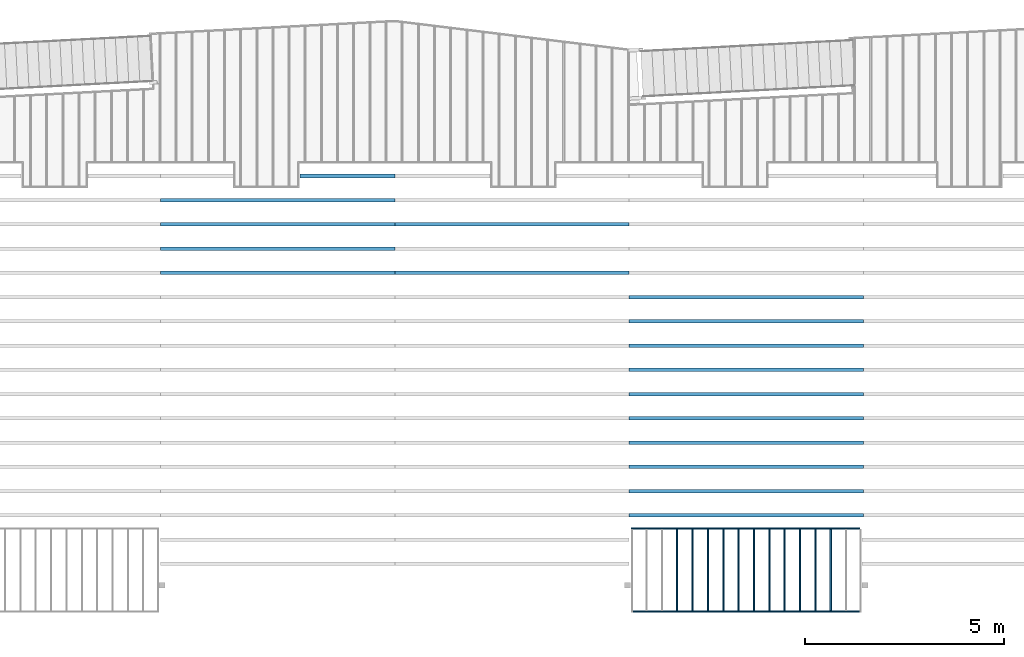
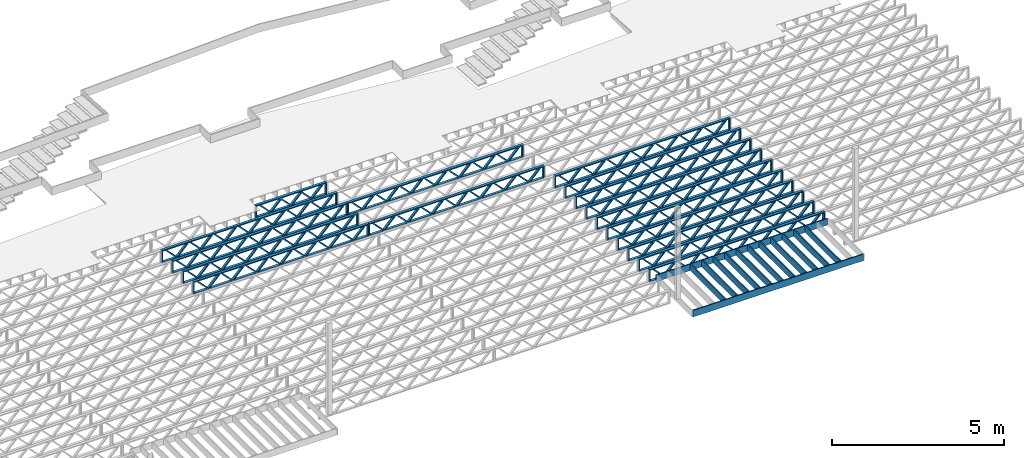
# One storey, part 7 of 23: 30 beams, 4 elements without a shape of their own.
"""IFC4 building model written with IfcOpenShell, lengths in feet."""

from ifc_helpers import new_model, entity, si_unit, converted_unit, derived_unit, direction, frame, frame_2d, origin, origin_2d_with_axis, place, context, subcontext, project, spatial, rectangle, extrude, source, transform, mapped, material, material_profile, profile_set, profile_usage, type_object, type_shapes, element, aggregate, save


model = new_model("IFC4")

# Units and contexts
model_context_1 = context("Model", 3, precision=0.0001, world=origin(), true_north=direction((6.12303176911189e-17, 1.0)))
model_context_2 = context("Model", 3, precision=0.0001, world=origin(), true_north=direction((6.12303176911189e-17, 1.0)))
body_context = subcontext(model_context_2, "Body", "Model", "MODEL_VIEW")
ifc_project = project(units=[converted_unit("LENGTHUNIT", "FOOT", entity("IfcRatioMeasure", 0.3048), si_unit("LENGTHUNIT", "METRE"), dimensions=[1, 0, 0, 0, 0, 0, 0]), converted_unit("AREAUNIT", "SQUARE FOOT", entity("IfcRatioMeasure", 0.09290304), si_unit("AREAUNIT", "SQUARE_METRE"), dimensions=[2, 0, 0, 0, 0, 0, 0]), converted_unit("VOLUMEUNIT", "CUBIC FOOT", entity("IfcRatioMeasure", 0.028316846592), si_unit("VOLUMEUNIT", "CUBIC_METRE"), dimensions=[3, 0, 0, 0, 0, 0, 0]), converted_unit("PLANEANGLEUNIT", "DEGREE", entity("IfcRatioMeasure", 0.0174532925199433), si_unit("PLANEANGLEUNIT", "RADIAN"), dimensions=[0, 0, 0, 0, 0, 0, 0]), si_unit("MASSUNIT", "GRAM", prefix="KILO"), derived_unit("MASSDENSITYUNIT", [(si_unit("MASSUNIT", "GRAM", prefix="KILO"), 1), (si_unit("LENGTHUNIT", "METRE"), -3)]), derived_unit("MOMENTOFINERTIAUNIT", [(si_unit("LENGTHUNIT", "METRE"), 4)]), si_unit("TIMEUNIT", "SECOND"), si_unit("FREQUENCYUNIT", "HERTZ"), si_unit("THERMODYNAMICTEMPERATUREUNIT", "DEGREE_CELSIUS"), derived_unit("THERMALTRANSMITTANCEUNIT", [(si_unit("MASSUNIT", "GRAM", prefix="KILO"), 1), (si_unit("THERMODYNAMICTEMPERATUREUNIT", "KELVIN"), -1), (si_unit("TIMEUNIT", "SECOND"), -3)]), derived_unit("VOLUMETRICFLOWRATEUNIT", [(si_unit("LENGTHUNIT", "METRE"), 3), (si_unit("TIMEUNIT", "SECOND"), -1)]), si_unit("ELECTRICCURRENTUNIT", "AMPERE"), si_unit("ELECTRICVOLTAGEUNIT", "VOLT"), si_unit("POWERUNIT", "WATT"), si_unit("FORCEUNIT", "NEWTON"), si_unit("ILLUMINANCEUNIT", "LUX"), si_unit("LUMINOUSFLUXUNIT", "LUMEN"), si_unit("LUMINOUSINTENSITYUNIT", "CANDELA"), derived_unit("USERDEFINED", [(si_unit("MASSUNIT", "GRAM", prefix="KILO"), -1), (si_unit("LENGTHUNIT", "METRE"), -2), (si_unit("TIMEUNIT", "SECOND"), 3), (si_unit("LUMINOUSFLUXUNIT", "LUMEN"), 1)]), derived_unit("LINEARVELOCITYUNIT", [(si_unit("LENGTHUNIT", "METRE"), 1), (si_unit("TIMEUNIT", "SECOND"), -1)]), si_unit("PRESSUREUNIT", "PASCAL"), derived_unit("USERDEFINED", [(si_unit("LENGTHUNIT", "METRE"), -2), (si_unit("MASSUNIT", "GRAM", prefix="KILO"), 1), (si_unit("TIMEUNIT", "SECOND"), -2)]), derived_unit("LINEARFORCEUNIT", [(si_unit("MASSUNIT", "GRAM", prefix="KILO"), 1), (si_unit("LENGTHUNIT", "METRE"), 1), (si_unit("TIMEUNIT", "SECOND"), -2), (si_unit("LENGTHUNIT", "METRE"), -1)]), derived_unit("PLANARFORCEUNIT", [(si_unit("MASSUNIT", "GRAM", prefix="KILO"), 1), (si_unit("LENGTHUNIT", "METRE"), 1), (si_unit("TIMEUNIT", "SECOND"), -2), (si_unit("LENGTHUNIT", "METRE"), -2)])], contexts=[model_context_1])

# Site, building, storey
site_placement = place(None, origin())
site = spatial("IfcSite", under=ifc_project, at=site_placement, CompositionType="ELEMENT")
building_placement = place(site_placement, origin())
building = spatial("IfcBuilding", under=site, at=building_placement, CompositionType="ELEMENT")
storey_placement = place(building_placement, frame((0.0, 0.0, 10.8020833333333)))
storey = spatial("IfcBuildingStorey", under=building, at=storey_placement, Name="2ND FLOOR", CompositionType="ELEMENT", Elevation=10.8020833333333)

# Assembly, beams
assembly_1_placement = place(storey_placement, origin())
assembly_1 = element("IfcElementAssembly", 1, at=assembly_1_placement, inside=storey, Name="Structural Beam System:Structural Framing System", ObjectType="Structural Beam System:Structural Framing System", AssemblyPlace="NOTDEFINED", PredefinedType="BEAM_GRID")
ifc_material_1 = material(Name="WOOD TRUSS", Category="Materials")
ifc_material_profile_1 = material_profile(ifc_material_1, rectangle(XDim=1.73473973950632, YDim=0.125, at=frame_2d((-1.11022302462516e-16, 8.32667268468867e-17), x_axis=(1.0, 0.0))))
ifc_material_profile_2 = material_profile(ifc_material_1, rectangle(XDim=1.73473973950633, YDim=0.125, at=frame_2d((-1.11022302462516e-16, 8.32667268468867e-17), x_axis=(1.0, 0.0))))
ifc_material_profile_3 = material_profile(ifc_material_1, rectangle(XDim=1.73473973950632, YDim=0.125, at=frame_2d((-5.55111512312578e-17, 1.38777878078145e-16), x_axis=(1.0, 0.0))))
ifc_material_profile_4 = material_profile(ifc_material_1, rectangle(XDim=1.73473973950633, YDim=0.125, at=frame_2d((-1.11022302462516e-16, 8.32667268468867e-17), x_axis=(1.0, 0.0))))
ifc_material_profile_5 = material_profile(ifc_material_1, rectangle(XDim=1.73473973950632, YDim=0.125, at=frame_2d((-1.11022302462516e-16, 8.32667268468867e-17), x_axis=(1.0, 0.0))))
ifc_material_profile_6 = material_profile(ifc_material_1, rectangle(XDim=1.73473973950633, YDim=0.125, at=frame_2d((-2.77555756156289e-16, 3.05311331771918e-16), x_axis=(1.0, 0.0))))
ifc_material_profile_7 = material_profile(ifc_material_1, rectangle(XDim=1.73473973950632, YDim=0.124999999999999, at=frame_2d((-3.88578058618805e-16, -2.4980018054066e-16), x_axis=(1.0, 0.0))))
ifc_material_profile_8 = material_profile(ifc_material_1, rectangle(XDim=1.73473973950633, YDim=0.125, at=frame_2d((2.77555756156289e-16, -3.05311331771918e-16), x_axis=(1.0, 0.0))))
ifc_material_profile_9 = material_profile(ifc_material_1, rectangle(XDim=1.73473973950632, YDim=0.124999999999999, at=frame_2d((-1.11022302462516e-16, 8.32667268468867e-17), x_axis=(1.0, 0.0))))
ifc_material_profile_10 = material_profile(ifc_material_1, rectangle(XDim=1.73473973950633, YDim=0.125, at=origin_2d_with_axis()))
ifc_material_profile_11 = material_profile(ifc_material_1, rectangle(XDim=0.124999999999982, YDim=0.291666666666668, at=origin_2d_with_axis()))
ifc_material_profile_12 = material_profile(ifc_material_1, rectangle(XDim=0.124999999999932, YDim=0.291666666666664, at=origin_2d_with_axis()))
ifc_material_profile_13 = material_profile(ifc_material_1, rectangle(XDim=1.25000000000002, YDim=0.29166666666667, at=origin_2d_with_axis()))
ifc_material_profile_14 = material_profile(ifc_material_1, rectangle(XDim=1.25000000000004, YDim=0.291666666666667, at=origin_2d_with_axis()))
ifc_profile_set_1 = profile_set([ifc_material_profile_1, ifc_material_profile_2, ifc_material_profile_3, ifc_material_profile_4, ifc_material_profile_5, ifc_material_profile_6, ifc_material_profile_7, ifc_material_profile_8, ifc_material_profile_9, ifc_material_profile_10, ifc_material_profile_11, ifc_material_profile_12, ifc_material_profile_13, ifc_material_profile_14])
ifc_profile_usage_1 = profile_usage(ifc_profile_set_1, cardinal=8)
beam_type_1 = type_object("IfcBeamType", PredefinedType="BEAM", material=ifc_profile_set_1)
shared_shape_1 = source(origin(), body_context, "Body", "SweptSolid", [
    extrude(rectangle(XDim=1.73473973950632, YDim=0.124999999999999, at=frame_2d((5.55111512312578e-16, 7.21644966006352e-16), x_axis=(1.0, 0.0))), frame((5.95847627016997, -0.145833333333334, 0.0), z_axis=(0.0, 1.0, 0.0), x_axis=(0.693383046997606, 0.0, 0.720569184836762)), (0.0, 0.0, 1.0), 0.291666666666667),
    extrude(rectangle(XDim=1.73473973950633, YDim=0.125, at=origin_2d_with_axis()), frame((4.7081903964967, -0.145833333333334, 0.0), z_axis=(0.0, 1.0, 0.0), x_axis=(0.69338304699761, 0.0, -0.720569184836758)), (0.0, 0.0, 1.0), 0.291666666666666),
    extrude(rectangle(XDim=1.73473973950632, YDim=0.125, at=frame_2d((2.22044604925031e-16, 3.88578058618805e-16), x_axis=(1.0, 0.0))), frame((3.29180960350347, -0.145833333333334, 0.0), z_axis=(0.0, 1.0, 0.0), x_axis=(0.693383046997606, 0.0, 0.720569184836762)), (0.0, 0.0, 1.0), 0.291666666666667),
    extrude(rectangle(XDim=1.73473973950633, YDim=0.125, at=frame_2d((1.11022302462516e-16, -8.32667268468867e-17), x_axis=(1.0, 0.0))), frame((2.0415237298302, -0.145833333333334, 0.0), z_axis=(0.0, 1.0, 0.0), x_axis=(0.69338304699761, 0.0, -0.720569184836758)), (0.0, 0.0, 1.0), 0.291666666666667),
    extrude(rectangle(XDim=1.73473973950632, YDim=0.125, at=frame_2d((-5.55111512312578e-17, 1.38777878078145e-16), x_axis=(1.0, 0.0))), frame((0.625142936836964, -0.145833333333334, 0.0), z_axis=(0.0, 1.0, 0.0), x_axis=(0.693383046997606, 0.0, 0.720569184836762)), (0.0, 0.0, 1.0), 0.291666666666667),
    extrude(rectangle(XDim=1.73473973950633, YDim=0.125, at=frame_2d((-1.11022302462516e-16, 8.32667268468867e-17), x_axis=(1.0, 0.0))), frame((-0.625142936836306, -0.145833333333334, 0.0), z_axis=(0.0, 1.0, 0.0), x_axis=(0.69338304699761, 0.0, -0.720569184836758)), (0.0, 0.0, 1.0), 0.291666666666667),
    extrude(rectangle(XDim=1.73473973950632, YDim=0.125, at=frame_2d((-1.11022302462516e-16, 8.32667268468867e-17), x_axis=(1.0, 0.0))), frame((-2.04152372982954, -0.145833333333334, 0.0), z_axis=(0.0, 1.0, 0.0), x_axis=(0.693383046997606, 0.0, 0.720569184836762)), (0.0, 0.0, 1.0), 0.291666666666667),
    extrude(rectangle(XDim=1.73473973950633, YDim=0.125, at=origin_2d_with_axis()), frame((-3.29180960350281, -0.145833333333334, 0.0), z_axis=(0.0, 1.0, 0.0), x_axis=(0.69338304699761, 0.0, -0.720569184836758)), (0.0, 0.0, 1.0), 0.291666666666667),
    extrude(rectangle(XDim=1.73473973950632, YDim=0.124999999999999, at=frame_2d((-1.11022302462516e-16, 8.32667268468867e-17), x_axis=(1.0, 0.0))), frame((-4.70819039649604, -0.145833333333334, 0.0), z_axis=(0.0, 1.0, 0.0), x_axis=(0.693383046997606, 0.0, 0.720569184836762)), (0.0, 0.0, 1.0), 0.291666666666667),
    extrude(rectangle(XDim=1.73473973950633, YDim=0.125, at=frame_2d((-5.55111512312578e-16, 6.38378239159465e-16), x_axis=(1.0, 0.0))), frame((-5.95847627016931, -0.145833333333334, 0.0), z_axis=(0.0, 1.0, 0.0), x_axis=(0.69338304699761, 0.0, -0.720569184836758)), (0.0, 0.0, 1.0), 0.291666666666666),
    extrude(rectangle(XDim=1.73473973950632, YDim=0.125, at=frame_2d((-7.21644966006352e-16, -5.82867087928207e-16), x_axis=(1.0, 0.0))), frame((8.62514293683647, -0.145833333333334, 0.0), z_axis=(0.0, 1.0, 0.0), x_axis=(0.693383046997607, 0.0, 0.720569184836761)), (0.0, 0.0, 1.0), 0.291666666666667),
    extrude(rectangle(XDim=1.73473973950633, YDim=0.125, at=origin_2d_with_axis()), frame((7.3748570631632, -0.145833333333334, 0.0), z_axis=(0.0, 1.0, 0.0), x_axis=(0.69338304699761, 0.0, -0.720569184836758)), (0.0, 0.0, 1.0), 0.291666666666666),
    extrude(rectangle(XDim=1.73473973950632, YDim=0.124999999999999, at=frame_2d((-1.11022302462516e-16, 8.32667268468867e-17), x_axis=(1.0, 0.0))), frame((-7.37485706316255, -0.145833333333334, 0.0), z_axis=(0.0, 1.0, 0.0), x_axis=(0.693383046997606, 0.0, 0.720569184836762)), (0.0, 0.0, 1.0), 0.291666666666667),
    extrude(rectangle(XDim=1.73473973950633, YDim=0.125, at=origin_2d_with_axis()), frame((-8.62514293683582, -0.145833333333334, 0.0), z_axis=(0.0, 1.0, 0.0), x_axis=(0.69338304699761, 0.0, -0.720569184836758)), (0.0, 0.0, 1.0), 0.291666666666666),
    extrude(rectangle(XDim=0.124999999999982, YDim=0.291666666666668, at=origin_2d_with_axis()), frame((-9.66666666666609, 0.0, 0.687500000000054), z_axis=(1.0, 0.0, 0.0), x_axis=(0.0, 0.0, -1.0)), (0.0, 0.0, 1.0), 19.3333333333322),
    extrude(rectangle(XDim=0.124999999999932, YDim=0.291666666666664, at=origin_2d_with_axis()), frame((-9.66666666666588, 0.0, -0.687499999999984), z_axis=(1.0, 0.0, 0.0), x_axis=(0.0, 0.0, -1.0)), (0.0, 0.0, 1.0), 19.333333333332),
    extrude(rectangle(XDim=1.25000000000002, YDim=0.29166666666667, at=origin_2d_with_axis()), frame((9.54166666666607, 0.0, 0.0), z_axis=(1.0, 0.0, 0.0), x_axis=(0.0, 0.0, -1.0)), (0.0, 0.0, 1.0), 0.12500000000002),
    extrude(rectangle(XDim=1.25000000000004, YDim=0.291666666666667, at=origin_2d_with_axis()), frame((-9.66666666666609, 0.0, 0.0), z_axis=(1.0, 0.0, 0.0), x_axis=(0.0, 0.0, -1.0)), (0.0, 0.0, 1.0), 0.125000000000023),
])
type_shapes(beam_type_1, [shared_shape_1])
beam_1_placement = place(assembly_1_placement, frame((-174.071493818896, 947.861934882651, -0.947916666666657), z_axis=(0.0, 0.0, 1.0), x_axis=(-1.0, 0.0, 0.0)))
beam_1 = element("IfcBeam", 2, at=beam_1_placement, type_object=beam_type_1, material=ifc_profile_usage_1, PredefinedType="BEAM", context=body_context, shape_type="MappedRepresentation", body=[
    mapped(shared_shape_1, transform((0.0, 0.0, 0.0), scale=1.0)),
])
ifc_profile_usage_2 = profile_usage(ifc_profile_set_1, cardinal=8)
beam_2_placement = place(assembly_1_placement, frame((-174.071493818896, 945.861934882651, -0.947916666666657), z_axis=(0.0, 0.0, 1.0), x_axis=(-1.0, 0.0, 0.0)))
beam_2 = element("IfcBeam", 3, at=beam_2_placement, type_object=beam_type_1, material=ifc_profile_usage_2, PredefinedType="BEAM", context=body_context, shape_type="MappedRepresentation", body=[
    mapped(shared_shape_1, transform((0.0, 0.0, 0.0), scale=1.0)),
])
ifc_profile_usage_3 = profile_usage(ifc_profile_set_1, cardinal=8)
beam_3_placement = place(assembly_1_placement, frame((-174.071493818896, 943.861934882651, -0.947916666666657), z_axis=(0.0, 0.0, 1.0), x_axis=(-1.0, 0.0, 0.0)))
beam_3 = element("IfcBeam", 4, at=beam_3_placement, type_object=beam_type_1, material=ifc_profile_usage_3, PredefinedType="BEAM", context=body_context, shape_type="MappedRepresentation", body=[
    mapped(shared_shape_1, transform((0.0, 0.0, 0.0), scale=1.0)),
])
ifc_profile_usage_4 = profile_usage(ifc_profile_set_1, cardinal=8)
beam_4_placement = place(assembly_1_placement, frame((-174.071493818896, 941.861934882651, -0.947916666666657), z_axis=(0.0, 0.0, 1.0), x_axis=(-1.0, 0.0, 0.0)))
beam_4 = element("IfcBeam", 5, at=beam_4_placement, type_object=beam_type_1, material=ifc_profile_usage_4, PredefinedType="BEAM", context=body_context, shape_type="MappedRepresentation", body=[
    mapped(shared_shape_1, transform((0.0, 0.0, 0.0), scale=1.0)),
])
ifc_profile_usage_5 = profile_usage(ifc_profile_set_1, cardinal=8)
beam_5_placement = place(assembly_1_placement, frame((-174.071493818896, 939.861934882651, -0.947916666666657), z_axis=(0.0, 0.0, 1.0), x_axis=(-1.0, 0.0, 0.0)))
beam_5 = element("IfcBeam", 6, at=beam_5_placement, type_object=beam_type_1, material=ifc_profile_usage_5, PredefinedType="BEAM", context=body_context, shape_type="MappedRepresentation", body=[
    mapped(shared_shape_1, transform((0.0, 0.0, 0.0), scale=1.0)),
])
ifc_profile_usage_6 = profile_usage(ifc_profile_set_1, cardinal=8)
beam_6_placement = place(assembly_1_placement, frame((-174.071493818896, 937.861934882651, -0.947916666666657), z_axis=(0.0, 0.0, 1.0), x_axis=(-1.0, 0.0, 0.0)))
beam_6 = element("IfcBeam", 7, at=beam_6_placement, type_object=beam_type_1, material=ifc_profile_usage_6, PredefinedType="BEAM", context=body_context, shape_type="MappedRepresentation", body=[
    mapped(shared_shape_1, transform((0.0, 0.0, 0.0), scale=1.0)),
])
ifc_profile_usage_7 = profile_usage(ifc_profile_set_1, cardinal=8)
beam_7_placement = place(assembly_1_placement, frame((-174.071493818896, 935.861934882651, -0.947916666666657), z_axis=(0.0, 0.0, 1.0), x_axis=(-1.0, 0.0, 0.0)))
beam_7 = element("IfcBeam", 8, at=beam_7_placement, type_object=beam_type_1, material=ifc_profile_usage_7, PredefinedType="BEAM", context=body_context, shape_type="MappedRepresentation", body=[
    mapped(shared_shape_1, transform((0.0, 0.0, 0.0), scale=1.0)),
])
ifc_profile_usage_8 = profile_usage(ifc_profile_set_1, cardinal=8)
beam_8_placement = place(assembly_1_placement, frame((-174.071493818896, 933.861934882651, -0.947916666666657), z_axis=(0.0, 0.0, 1.0), x_axis=(-1.0, 0.0, 0.0)))
beam_8 = element("IfcBeam", 9, at=beam_8_placement, type_object=beam_type_1, material=ifc_profile_usage_8, PredefinedType="BEAM", context=body_context, shape_type="MappedRepresentation", body=[
    mapped(shared_shape_1, transform((0.0, 0.0, 0.0), scale=1.0)),
])
ifc_profile_usage_9 = profile_usage(ifc_profile_set_1, cardinal=8)
beam_9_placement = place(assembly_1_placement, frame((-174.071493818896, 931.861934882651, -0.947916666666657), z_axis=(0.0, 0.0, 1.0), x_axis=(-1.0, 0.0, 0.0)))
beam_9 = element("IfcBeam", 10, at=beam_9_placement, type_object=beam_type_1, material=ifc_profile_usage_9, PredefinedType="BEAM", context=body_context, shape_type="MappedRepresentation", body=[
    mapped(shared_shape_1, transform((0.0, 0.0, 0.0), scale=1.0)),
])
ifc_profile_usage_10 = profile_usage(ifc_profile_set_1, cardinal=8)
beam_10_placement = place(assembly_1_placement, frame((-174.071493818896, 929.861934882651, -0.947916666666657), z_axis=(0.0, 0.0, 1.0), x_axis=(-1.0, 0.0, 0.0)))
beam_10 = element("IfcBeam", 11, at=beam_10_placement, type_object=beam_type_1, material=ifc_profile_usage_10, PredefinedType="BEAM", context=body_context, shape_type="MappedRepresentation", body=[
    mapped(shared_shape_1, transform((0.0, 0.0, 0.0), scale=1.0)),
])
aggregate(assembly_1, [beam_1, beam_2, beam_3, beam_4, beam_5, beam_6, beam_7, beam_8, beam_9, beam_10])

assembly_2_placement = place(storey_placement, origin())
assembly_2 = element("IfcElementAssembly", 12, at=assembly_2_placement, inside=storey, Name="Structural Beam System:Structural Framing System", ObjectType="Structural Beam System:Structural Framing System", AssemblyPlace="NOTDEFINED", PredefinedType="BEAM_GRID")
ifc_profile_usage_11 = profile_usage(ifc_profile_set_1, cardinal=8)
beam_11_placement = place(assembly_2_placement, frame((-193.404827152229, 953.861934882651, -0.947916666666881)))
beam_11 = element("IfcBeam", 13, at=beam_11_placement, type_object=beam_type_1, material=ifc_profile_usage_11, PredefinedType="BEAM", context=body_context, shape_type="MappedRepresentation", body=[
    mapped(shared_shape_1, transform((0.0, 0.0, 0.0), scale=1.0)),
])
ifc_profile_usage_12 = profile_usage(ifc_profile_set_1, cardinal=8)
beam_12_placement = place(assembly_2_placement, frame((-193.404827152229, 949.861934882651, -0.947916666666881)))
beam_12 = element("IfcBeam", 14, at=beam_12_placement, type_object=beam_type_1, material=ifc_profile_usage_12, PredefinedType="BEAM", context=body_context, shape_type="MappedRepresentation", body=[
    mapped(shared_shape_1, transform((0.0, 0.0, 0.0), scale=1.0)),
])
aggregate(assembly_2, [beam_11, beam_12])

assembly_3_placement = place(storey_placement, origin())
assembly_3 = element("IfcElementAssembly", 15, at=assembly_3_placement, inside=storey, Name="Structural Beam System:Structural Framing System", ObjectType="Structural Beam System:Structural Framing System", AssemblyPlace="NOTDEFINED", PredefinedType="BEAM_GRID")
ifc_profile_usage_13 = profile_usage(ifc_profile_set_1, cardinal=8)
beam_13_placement = place(assembly_3_placement, frame((-212.738160485495, 955.861934882651, -0.947916666666881), z_axis=(0.0, 0.0, 1.0), x_axis=(-1.0, 0.0, 0.0)))
beam_13 = element("IfcBeam", 16, at=beam_13_placement, type_object=beam_type_1, material=ifc_profile_usage_13, PredefinedType="BEAM", context=body_context, shape_type="MappedRepresentation", body=[
    mapped(shared_shape_1, transform((0.0, 0.0, 0.0), scale=1.0)),
])
ifc_profile_usage_14 = profile_usage(ifc_profile_set_1, cardinal=8)
beam_14_placement = place(assembly_3_placement, frame((-212.738160485495, 953.861934882651, -0.947916666666881), z_axis=(0.0, 0.0, 1.0), x_axis=(-1.0, 0.0, 0.0)))
beam_14 = element("IfcBeam", 17, at=beam_14_placement, type_object=beam_type_1, material=ifc_profile_usage_14, PredefinedType="BEAM", context=body_context, shape_type="MappedRepresentation", body=[
    mapped(shared_shape_1, transform((0.0, 0.0, 0.0), scale=1.0)),
])
ifc_profile_usage_15 = profile_usage(ifc_profile_set_1, cardinal=8)
beam_15_placement = place(assembly_3_placement, frame((-212.738160485495, 951.861934882651, -0.947916666666881), z_axis=(0.0, 0.0, 1.0), x_axis=(-1.0, 0.0, 0.0)))
beam_15 = element("IfcBeam", 18, at=beam_15_placement, type_object=beam_type_1, material=ifc_profile_usage_15, PredefinedType="BEAM", context=body_context, shape_type="MappedRepresentation", body=[
    mapped(shared_shape_1, transform((0.0, 0.0, 0.0), scale=1.0)),
])
ifc_profile_usage_16 = profile_usage(ifc_profile_set_1, cardinal=8)
beam_16_placement = place(assembly_3_placement, frame((-212.738160485495, 949.861934882651, -0.947916666666881), z_axis=(0.0, 0.0, 1.0), x_axis=(-1.0, 0.0, 0.0)))
beam_16 = element("IfcBeam", 19, at=beam_16_placement, type_object=beam_type_1, material=ifc_profile_usage_16, PredefinedType="BEAM", context=body_context, shape_type="MappedRepresentation", body=[
    mapped(shared_shape_1, transform((0.0, 0.0, 0.0), scale=1.0)),
])

assembly_4_placement = place(storey_placement, origin())
assembly_4 = element("IfcElementAssembly", 20, at=assembly_4_placement, inside=storey, Name="Structural Beam System:Structural Framing System", ObjectType="Structural Beam System:Structural Framing System", AssemblyPlace="NOTDEFINED", PredefinedType="BEAM_GRID")
ifc_material_2 = material(Category="Materials")
ifc_material_profile_15 = material_profile(ifc_material_2, rectangle(XDim=0.770833333333333, YDim=0.124999999999994, at=frame_2d((-5.55111512312578e-17, 0.0), x_axis=(1.0, 0.0))))
ifc_profile_set_2 = profile_set([ifc_material_profile_15])
ifc_profile_usage_17 = profile_usage(ifc_profile_set_2, cardinal=8)
beam_type_2 = type_object("IfcBeamType", PredefinedType="BEAM", material=ifc_profile_set_2)
shared_shape_2 = source(origin(), body_context, "Body", "SweptSolid", [
    extrude(rectangle(XDim=0.770833333333333, YDim=0.124999999999994, at=frame_2d((-5.55111512312578e-17, 0.0), x_axis=(1.0, 0.0))), frame((-3.35416666666737, 0.0, 0.0), z_axis=(1.0, 0.0, 0.0), x_axis=(0.0, 0.0, -1.0)), (0.0, 0.0, 1.0), 6.70833333333462),
])
type_shapes(beam_type_2, [shared_shape_2])
beam_17_placement = place(assembly_4_placement, frame((-167.102006703188, 925.341101549316, -0.645833333333471), z_axis=(0.0, 0.0, 1.0), x_axis=(0.0, 1.0, 0.0)))
beam_17 = element("IfcBeam", 21, at=beam_17_placement, type_object=beam_type_2, material=ifc_profile_usage_17, PredefinedType="BEAM", context=body_context, shape_type="MappedRepresentation", body=[
    mapped(shared_shape_2, transform((0.0, 0.0, 0.0), scale=1.0)),
])
ifc_profile_usage_18 = profile_usage(ifc_profile_set_2, cardinal=8)
beam_18_placement = place(assembly_4_placement, frame((-168.368890383746, 925.341101549316, -0.645833333333471), z_axis=(0.0, 0.0, 1.0), x_axis=(0.0, 1.0, 0.0)))
beam_18 = element("IfcBeam", 22, at=beam_18_placement, type_object=beam_type_2, material=ifc_profile_usage_18, PredefinedType="BEAM", context=body_context, shape_type="MappedRepresentation", body=[
    mapped(shared_shape_2, transform((0.0, 0.0, 0.0), scale=1.0)),
])
ifc_profile_usage_19 = profile_usage(ifc_profile_set_2, cardinal=8)
beam_19_placement = place(assembly_4_placement, frame((-169.635774064305, 925.341101549317, -0.645833333333471), z_axis=(0.0, 0.0, 1.0), x_axis=(0.0, 1.0, 0.0)))
beam_19 = element("IfcBeam", 23, at=beam_19_placement, type_object=beam_type_2, material=ifc_profile_usage_19, PredefinedType="BEAM", context=body_context, shape_type="MappedRepresentation", body=[
    mapped(shared_shape_2, transform((0.0, 0.0, 0.0), scale=1.0)),
])
ifc_profile_usage_20 = profile_usage(ifc_profile_set_2, cardinal=8)
beam_20_placement = place(assembly_4_placement, frame((-170.902657744863, 925.341101549317, -0.645833333333471), z_axis=(0.0, 0.0, 1.0), x_axis=(0.0, 1.0, 0.0)))
beam_20 = element("IfcBeam", 24, at=beam_20_placement, type_object=beam_type_2, material=ifc_profile_usage_20, PredefinedType="BEAM", context=body_context, shape_type="MappedRepresentation", body=[
    mapped(shared_shape_2, transform((0.0, 0.0, 0.0), scale=1.0)),
])
ifc_profile_usage_21 = profile_usage(ifc_profile_set_2, cardinal=8)
beam_21_placement = place(assembly_4_placement, frame((-172.169541425421, 925.341101549317, -0.645833333333471), z_axis=(0.0, 0.0, 1.0), x_axis=(0.0, 1.0, 0.0)))
beam_21 = element("IfcBeam", 25, at=beam_21_placement, type_object=beam_type_2, material=ifc_profile_usage_21, PredefinedType="BEAM", context=body_context, shape_type="MappedRepresentation", body=[
    mapped(shared_shape_2, transform((0.0, 0.0, 0.0), scale=1.0)),
])
ifc_profile_usage_22 = profile_usage(ifc_profile_set_2, cardinal=8)
beam_22_placement = place(assembly_4_placement, frame((-173.43642510598, 925.341101549317, -0.645833333333471), z_axis=(0.0, 0.0, 1.0), x_axis=(0.0, 1.0, 0.0)))
beam_22 = element("IfcBeam", 26, at=beam_22_placement, type_object=beam_type_2, material=ifc_profile_usage_22, PredefinedType="BEAM", context=body_context, shape_type="MappedRepresentation", body=[
    mapped(shared_shape_2, transform((0.0, 0.0, 0.0), scale=1.0)),
])
ifc_profile_usage_23 = profile_usage(ifc_profile_set_2, cardinal=8)
beam_23_placement = place(assembly_4_placement, frame((-174.703308786538, 925.341101549318, -0.645833333333433), z_axis=(0.0, 0.0, 1.0), x_axis=(0.0, 1.0, 0.0)))
beam_23 = element("IfcBeam", 27, at=beam_23_placement, type_object=beam_type_2, material=ifc_profile_usage_23, PredefinedType="BEAM", context=body_context, shape_type="MappedRepresentation", body=[
    mapped(shared_shape_2, transform((0.0, 0.0, 0.0), scale=1.0)),
])
ifc_profile_usage_24 = profile_usage(ifc_profile_set_2, cardinal=8)
beam_24_placement = place(assembly_4_placement, frame((-175.970192467096, 925.341101549318, -0.645833333333471), z_axis=(0.0, 0.0, 1.0), x_axis=(0.0, 1.0, 0.0)))
beam_24 = element("IfcBeam", 28, at=beam_24_placement, type_object=beam_type_2, material=ifc_profile_usage_24, PredefinedType="BEAM", context=body_context, shape_type="MappedRepresentation", body=[
    mapped(shared_shape_2, transform((0.0, 0.0, 0.0), scale=1.0)),
])
ifc_profile_usage_25 = profile_usage(ifc_profile_set_2, cardinal=8)
beam_25_placement = place(assembly_4_placement, frame((-177.237076147655, 925.341101549318, -0.645833333333471), z_axis=(0.0, 0.0, 1.0), x_axis=(0.0, 1.0, 0.0)))
beam_25 = element("IfcBeam", 29, at=beam_25_placement, type_object=beam_type_2, material=ifc_profile_usage_25, PredefinedType="BEAM", context=body_context, shape_type="MappedRepresentation", body=[
    mapped(shared_shape_2, transform((0.0, 0.0, 0.0), scale=1.0)),
])
ifc_profile_usage_26 = profile_usage(ifc_profile_set_2, cardinal=8)
beam_26_placement = place(assembly_4_placement, frame((-178.503959828213, 925.341101549318, -0.645833333333471), z_axis=(0.0, 0.0, 1.0), x_axis=(0.0, 1.0, 0.0)))
beam_26 = element("IfcBeam", 30, at=beam_26_placement, type_object=beam_type_2, material=ifc_profile_usage_26, PredefinedType="BEAM", context=body_context, shape_type="MappedRepresentation", body=[
    mapped(shared_shape_2, transform((0.0, 0.0, 0.0), scale=1.0)),
])
ifc_profile_usage_27 = profile_usage(ifc_profile_set_2, cardinal=8)
beam_27_placement = place(assembly_4_placement, frame((-179.770843508771, 925.341101549318, -0.645833333333471), z_axis=(0.0, 0.0, 1.0), x_axis=(0.0, 1.0, 0.0)))
beam_27 = element("IfcBeam", 31, at=beam_27_placement, type_object=beam_type_2, material=ifc_profile_usage_27, PredefinedType="BEAM", context=body_context, shape_type="MappedRepresentation", body=[
    mapped(shared_shape_2, transform((0.0, 0.0, 0.0), scale=1.0)),
])
aggregate(assembly_4, [beam_17, beam_18, beam_19, beam_20, beam_21, beam_22, beam_23, beam_24, beam_25, beam_26, beam_27])

# Beams
ifc_material_3 = material(Name="BRAKE METAL FLASHING AT PERIMETER 2X LEDGER", Category="Materials")
ifc_material_profile_16 = material_profile(ifc_material_3, rectangle(XDim=0.770833333333333, YDim=0.124999999999994, at=frame_2d((-1.11022302462516e-16, 0.0), x_axis=(1.0, 0.0))), Name="BRAKE METAL FLASHING AT PERIMETER 2X LEDGER")
ifc_profile_set_3 = profile_set([ifc_material_profile_16], Name="BRAKE METAL FLASHING AT PERIMETER 2X LEDGER")
ifc_profile_usage_28 = profile_usage(ifc_profile_set_3, cardinal=8)
beam_type_3 = type_object("IfcBeamType", PredefinedType="BEAM", material=ifc_profile_set_3)
shared_shape_3 = source(origin(), body_context, "Body", "SweptSolid", [
    extrude(rectangle(XDim=0.770833333333333, YDim=0.124999999999994, at=frame_2d((-1.11022302462516e-16, 0.0), x_axis=(1.0, 0.0))), frame((-9.37499887751909, 0.0, 0.0), z_axis=(1.0, 0.0, 0.0), x_axis=(0.0, 0.0, -1.0)), (0.0, 0.0, 1.0), 18.7499977550382),
])
type_shapes(beam_type_3, [shared_shape_3])
beam_28_placement = place(storey_placement, frame((-174.071492696381, 921.92443488265, -0.645833333333494)))
element("IfcBeam", 32, at=beam_28_placement, inside=storey, type_object=beam_type_3, material=ifc_profile_usage_28, PredefinedType="BEAM", context=body_context, shape_type="MappedRepresentation", body=[
    mapped(shared_shape_3, transform((0.0, 0.0, 0.0), scale=1.0)),
])
ifc_profile_usage_29 = profile_usage(ifc_profile_set_2, cardinal=8)
beam_type_4 = type_object("IfcBeamType", PredefinedType="BEAM", material=ifc_profile_set_2)
shared_shape_4 = source(origin(), body_context, "Body", "SweptSolid", [
    extrude(rectangle(XDim=0.770833333333333, YDim=0.124999999999994, at=frame_2d((-1.11022302462516e-16, 0.0), x_axis=(1.0, 0.0))), frame((-9.49999887751909, 0.0, 0.0), z_axis=(1.0, 0.0, 0.0), x_axis=(0.0, 0.0, -1.0)), (0.0, 0.0, 1.0), 18.8749977550382),
])
type_shapes(beam_type_4, [shared_shape_4])
beam_29_placement = place(storey_placement, frame((-174.071492696381, 928.757768215985, -0.645833333333506)))
element("IfcBeam", 33, at=beam_29_placement, inside=storey, type_object=beam_type_4, material=ifc_profile_usage_29, PredefinedType="BEAM", context=body_context, shape_type="MappedRepresentation", body=[
    mapped(shared_shape_4, transform((0.0, 0.0, 0.0), scale=1.0)),
])

# Beam
ifc_profile_usage_30 = profile_usage(ifc_profile_set_1, cardinal=8)
beam_type_5 = type_object("IfcBeamType", PredefinedType="BEAM", material=ifc_profile_set_1)
shared_shape_5 = source(origin(), body_context, "Body", "SweptSolid", [
    extrude(rectangle(XDim=1.73473973950632, YDim=0.125, at=frame_2d((-5.55111512312578e-17, 1.38777878078145e-16), x_axis=(1.0, 0.0))), frame((0.625142936836963, -0.145833333333334, 0.0), z_axis=(0.0, 1.0, 0.0), x_axis=(0.693383046997606, 0.0, 0.720569184836762)), (0.0, 0.0, 1.0), 0.291666666666667),
    extrude(rectangle(XDim=1.73473973950633, YDim=0.125, at=frame_2d((-1.11022302462516e-16, 8.32667268468867e-17), x_axis=(1.0, 0.0))), frame((-0.625142936836308, -0.145833333333334, 0.0), z_axis=(0.0, 1.0, 0.0), x_axis=(0.69338304699761, 0.0, -0.720569184836758)), (0.0, 0.0, 1.0), 0.291666666666667),
    extrude(rectangle(XDim=1.73473973950632, YDim=0.125, at=frame_2d((-1.11022302462516e-16, 8.32667268468867e-17), x_axis=(1.0, 0.0))), frame((2.87514285312432, -0.145833333333334, 0.0), z_axis=(0.0, 1.0, 0.0), x_axis=(0.693383046997606, 0.0, 0.720569184836762)), (0.0, 0.0, 1.0), 0.291666666666667),
    extrude(rectangle(XDim=1.73473973950633, YDim=0.125, at=frame_2d((-1.11022302462516e-16, 8.32667268468867e-17), x_axis=(1.0, 0.0))), frame((1.62485697945105, -0.145833333333334, 0.0), z_axis=(0.0, 1.0, 0.0), x_axis=(0.69338304699761, 0.0, -0.720569184836758)), (0.0, 0.0, 1.0), 0.291666666666667),
    extrude(rectangle(XDim=1.73473973950632, YDim=0.125, at=frame_2d((-1.11022302462516e-16, 8.32667268468867e-17), x_axis=(1.0, 0.0))), frame((-1.62485697945039, -0.145833333333334, 0.0), z_axis=(0.0, 1.0, 0.0), x_axis=(0.693383046997606, 0.0, 0.720569184836762)), (0.0, 0.0, 1.0), 0.291666666666667),
    extrude(rectangle(XDim=1.73473973950633, YDim=0.125, at=origin_2d_with_axis()), frame((-2.87514285312366, -0.145833333333334, 0.0), z_axis=(0.0, 1.0, 0.0), x_axis=(0.69338304699761, 0.0, -0.720569184836758)), (0.0, 0.0, 1.0), 0.291666666666667),
    extrude(rectangle(XDim=0.124999999999982, YDim=0.291666666666668, at=origin_2d_with_axis()), frame((-3.91666658295394, 0.0, 0.687500000000054), z_axis=(1.0, 0.0, 0.0), x_axis=(0.0, 0.0, -1.0)), (0.0, 0.0, 1.0), 7.83333316590787),
    extrude(rectangle(XDim=0.124999999999932, YDim=0.291666666666664, at=origin_2d_with_axis()), frame((-3.91666658295372, 0.0, -0.687499999999984), z_axis=(1.0, 0.0, 0.0), x_axis=(0.0, 0.0, -1.0)), (0.0, 0.0, 1.0), 7.83333316590766),
    extrude(rectangle(XDim=1.25000000000002, YDim=0.29166666666667, at=origin_2d_with_axis()), frame((3.79166658295392, 0.0, 0.0), z_axis=(1.0, 0.0, 0.0), x_axis=(0.0, 0.0, -1.0)), (0.0, 0.0, 1.0), 0.12500000000002),
    extrude(rectangle(XDim=1.25000000000004, YDim=0.291666666666667, at=origin_2d_with_axis()), frame((-3.91666658295394, 0.0, 0.0), z_axis=(1.0, 0.0, 0.0), x_axis=(0.0, 0.0, -1.0)), (0.0, 0.0, 1.0), 0.125000000000023),
])
type_shapes(beam_type_5, [shared_shape_5])
beam_30_placement = place(assembly_3_placement, frame((-206.988160401783, 957.861934882651, -0.947916666666881), z_axis=(0.0, 0.0, 1.0), x_axis=(-1.0, 0.0, 0.0)))
beam_30 = element("IfcBeam", 34, at=beam_30_placement, type_object=beam_type_5, material=ifc_profile_usage_30, PredefinedType="BEAM", context=body_context, shape_type="MappedRepresentation", body=[
    mapped(shared_shape_5, transform((0.0, 0.0, 0.0), scale=1.0)),
])

aggregate(assembly_3, [beam_13, beam_14, beam_15, beam_16, beam_30])

save(model, "model.ifc")
